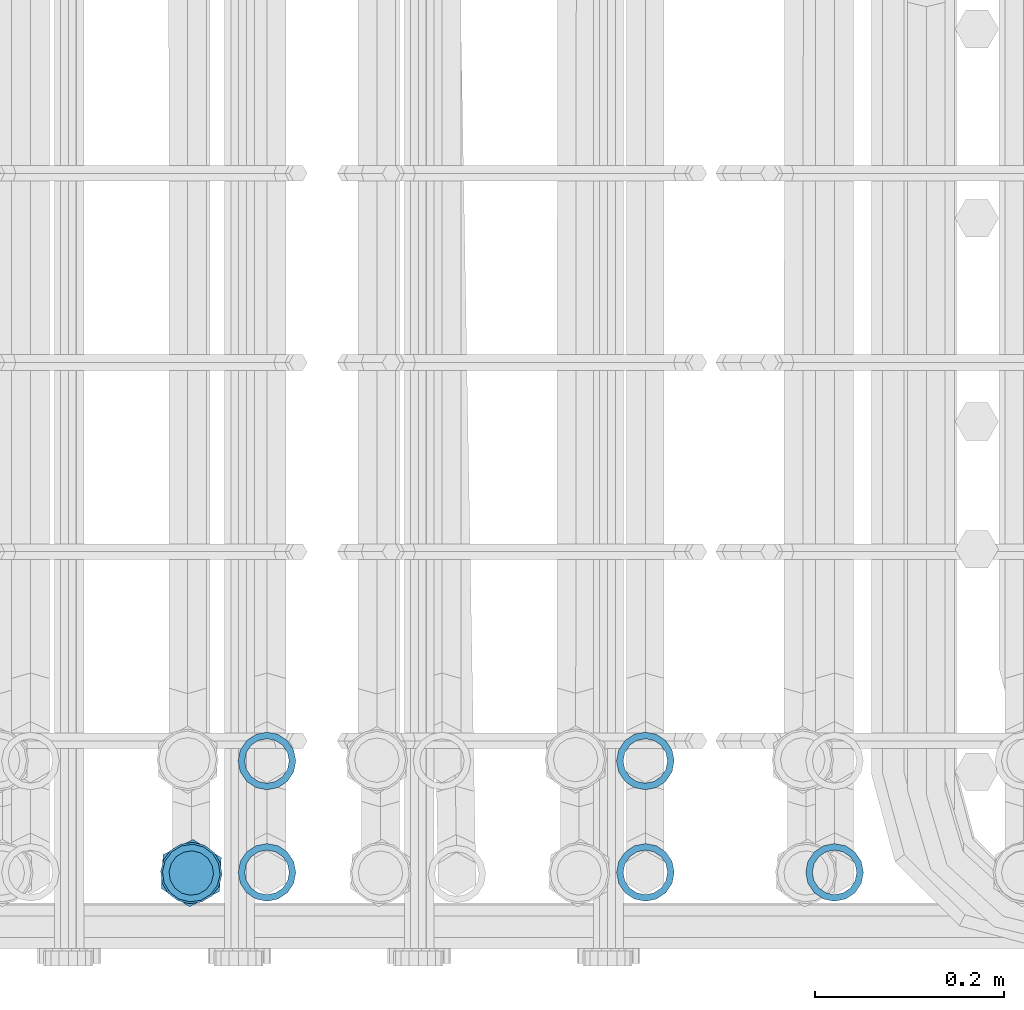
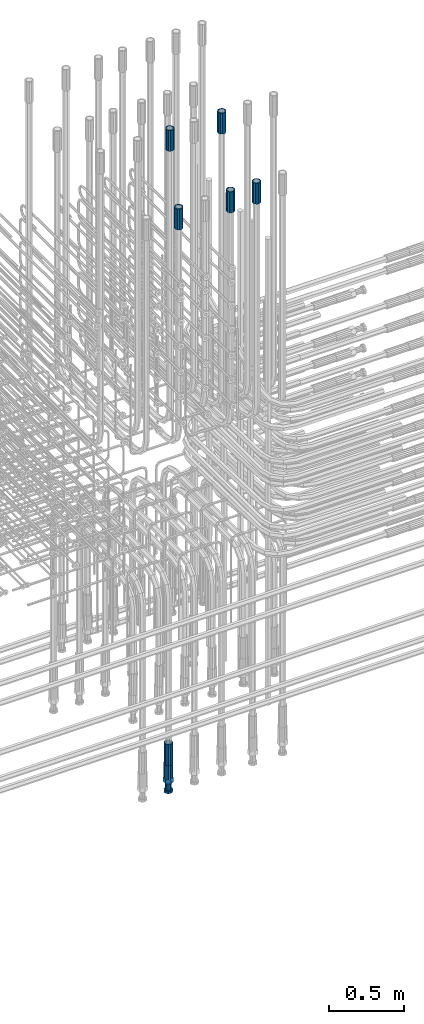
# One storey, part 93 of 177: 7 beams.
"""IFC2X3 building model written with IfcOpenShell, lengths in millimetres."""

import ifcopenshell
import ifcopenshell.guid

model = None  # the IFC model being written
_history = None  # IfcOwnerHistory: only IFC2X3 demands one
_inside = {}  # id of a spatial element -> (the spatial element, [elements in it])
_under = {}  # id of a project, library or spatial element -> (it, [spatial elements below it])
_declared = {}  # id of a project -> (the project, [libraries it declares])
_typed = {}  # id of a type object -> (the type object, [elements of that type])
_made_of = {}  # id of a material, layer set ... -> (it, [elements and type objects made of it])


def new_model(schema):
    """Start an empty IFC model of exactly this schema.

    Asked for "IFC4X3", IfcOpenShell would pick the latest addendum, in which some entities
    have other attributes; the version numbers below select the first issue.
    IFC2X3 requires an IfcOwnerHistory on every rooted entity: one is made here for all.
    """
    global model, _history
    if schema == "IFC4X3":
        model = ifcopenshell.file(schema_version=(4, 3, 0, 0))
    else:
        model = ifcopenshell.file(schema=schema)
    _inside.clear()
    _under.clear()
    _declared.clear()
    _typed.clear()
    _made_of.clear()
    _history = None
    if model.schema == "IFC2X3":
        org = make("IfcOrganization", Name="unknown")
        user = make(
            "IfcPersonAndOrganization",
            ThePerson=make("IfcPerson", FamilyName="unknown"),
            TheOrganization=org,
        )
        app = make(
            "IfcApplication",
            ApplicationDeveloper=org,
            Version="unknown",
            ApplicationFullName="unknown",
            ApplicationIdentifier="unknown",
        )
        _history = make(
            "IfcOwnerHistory",
            OwningUser=user,
            OwningApplication=app,
            ChangeAction="ADDED",
            CreationDate=0,
        )
    return model


def make(cls, **values):
    """One entity of the class cls with the attributes given. An attribute that is None is left unset."""
    return model.create_entity(
        cls, **{name: value for name, value in values.items() if value is not None}
    )


def rooted(cls, **values):
    """An entity with a GlobalId (a new one), such as an element, a storey or a relation."""
    return make(cls, GlobalId=ifcopenshell.guid.new(), OwnerHistory=_history, **values)


def si_unit(unit_type, name, prefix=None):
    """IfcSIUnit, for example si_unit("LENGTHUNIT", "METRE", prefix="MILLI")."""
    return make("IfcSIUnit", UnitType=unit_type, Prefix=prefix, Name=name)


def assignment(units):
    """IfcUnitAssignment: the units of a project."""
    return None if units is None else make("IfcUnitAssignment", Units=units)


def point(xyz):
    """IfcCartesianPoint."""
    return None if xyz is None else make("IfcCartesianPoint", Coordinates=xyz)


def direction(xyz):
    """IfcDirection."""
    return None if xyz is None else make("IfcDirection", DirectionRatios=xyz)


def frame(location, z_axis=None, x_axis=None):
    """IfcAxis2Placement3D, a coordinate frame: its origin and axes. An axis left out is left unset."""
    return make(
        "IfcAxis2Placement3D",
        Location=point(location),
        Axis=direction(z_axis),
        RefDirection=direction(x_axis),
    )


def origin_with_axes():
    """The frame at (0, 0, 0) with the z axis (0, 0, 1) and the x axis (1, 0, 0) written out."""
    return frame((0.0, 0.0, 0.0), z_axis=(0.0, 0.0, 1.0), x_axis=(1.0, 0.0, 0.0))


def place(relative_to, where):
    """IfcLocalPlacement: puts the frame where relative to a parent placement (None: the world)."""
    return make(
        "IfcLocalPlacement", PlacementRelTo=relative_to, RelativePlacement=where
    )


def context(
    kind, dimensions, precision=None, world=None, true_north=None, identifier=None
):
    """IfcGeometricRepresentationContext, for example the 3D "Model" context."""
    return make(
        "IfcGeometricRepresentationContext",
        ContextIdentifier=identifier,
        ContextType=kind,
        CoordinateSpaceDimension=dimensions,
        Precision=precision,
        WorldCoordinateSystem=world,
        TrueNorth=true_north,
    )


def subcontext(parent, identifier, kind, view, scale=None):
    """IfcGeometricRepresentationSubContext, for example "Body" below "Model"."""
    return make(
        "IfcGeometricRepresentationSubContext",
        ContextIdentifier=identifier,
        ContextType=kind,
        ParentContext=parent,
        TargetScale=scale,
        TargetView=view,
    )


def project(units=None, contexts=None):
    """IfcProject with its units and contexts."""
    return rooted(
        "IfcProject",
        Name="project",
        RepresentationContexts=contexts,
        UnitsInContext=assignment(units),
    )


def spatial(cls, under=None, at=None, **own):
    """A site, building, storey or space (cls), placed at a placement, below another one or the project."""
    s = rooted(cls, ObjectPlacement=at, **own)
    if under is not None:
        _under.setdefault(under.id(), (under, []))[1].append(s)
    return s


def faces_of(points, faces, orient=None, outer=None):
    """IfcFace entities. A face is a list of loops; a loop is a list of indices into points, from 0.

    orient and outer hold one flag for each loop. By default every Orientation is true, the
    first loop of a face is its IfcFaceOuterBound and the others are IfcFaceBound.
    """
    made = []
    for i, loops in enumerate(faces):
        bounds = []
        for j, loop in enumerate(loops):
            is_outer = j == 0 if outer is None else outer[i][j]
            bounds.append(
                make(
                    "IfcFaceOuterBound" if is_outer else "IfcFaceBound",
                    Bound=make("IfcPolyLoop", Polygon=[points[k] for k in loop]),
                    Orientation=True if orient is None else orient[i][j],
                )
            )
        made.append(make("IfcFace", Bounds=bounds))
    return made


def faceted_brep(points, faces, orient=None, outer=None, voids=None):
    """IfcFacetedBrep: a solid bounded by flat faces; with voids (closed shells), ...WithVoids."""
    shared = [point(p) for p in points]
    hull = make("IfcClosedShell", CfsFaces=faces_of(shared, faces, orient, outer))
    if voids is None:
        return make("IfcFacetedBrep", Outer=hull)
    return make(
        "IfcFacetedBrepWithVoids",
        Outer=hull,
        Voids=[
            make(cls, CfsFaces=faces_of(shared, fs, o, b)) for cls, fs, o, b in voids
        ],
    )


def shape(context_of_items, identifier, shape_type, items):
    """IfcShapeRepresentation: the items that make up one representation, for example the "Body"."""
    return make(
        "IfcShapeRepresentation",
        ContextOfItems=context_of_items,
        RepresentationIdentifier=identifier,
        RepresentationType=shape_type,
        Items=items,
    )


def material(Name=None, Category=None):
    """IfcMaterial."""
    return make("IfcMaterial", Name=Name, Category=Category)


def made_of(thing, what):
    """Note that an element or type object is made of a material, layer set ...; save() writes the relation."""
    if what is not None:
        _made_of.setdefault(what.id(), (what, []))[1].append(thing)
    return thing


def type_object(cls, material=None, **own):
    """A type object (cls), such as IfcWallType, which elements share."""
    return made_of(rooted(cls, **own), material)


def element(
    cls,
    number,
    at=None,
    inside=None,
    cuts=None,
    type_object=None,
    material=None,
    context=None,
    identifier="Body",
    shape_type=None,
    held_by="IfcProductDefinitionShape",
    body=None,
    shapes=None,
    **own,
):
    """One element of the class cls, such as IfcWall. Its Tag is "e" and its number.

    at: its placement. inside: the storey or other place that contains it. cuts: it is an
    opening in that element (IfcRelVoidsElement). A single representation is given by context,
    identifier, shape_type and body (its items); several are given by shapes. held_by: the class
    of the entity that holds the representations. save() writes the other relations.
    """
    e = rooted(cls, Tag="e%d" % number, ObjectPlacement=at, **own)
    if body is not None:
        shapes = [shape(context, identifier, shape_type, body)]
    if shapes is not None:
        e.Representation = make(held_by, Representations=shapes)
    if inside is not None:
        _inside.setdefault(inside.id(), (inside, []))[1].append(e)
    if cuts is not None:
        rooted(
            "IfcRelVoidsElement", RelatingBuildingElement=cuts, RelatedOpeningElement=e
        )
    if type_object is not None:
        _typed.setdefault(type_object.id(), (type_object, []))[1].append(e)
    return made_of(e, material)


def aggregate(whole, parts):
    """IfcRelAggregates: a whole, such as a stair, and the parts it consists of."""
    return rooted("IfcRelAggregates", RelatingObject=whole, RelatedObjects=parts)


def save(model, path):
    """Write the relations noted so far, then the file.

    IfcRelAggregates (storeys below a building ...), IfcRelContainedInSpatialStructure (elements
    in a storey), IfcRelDefinesByType, IfcRelAssociatesMaterial and IfcRelDeclares: one each for
    every whole, place, type object, material and project.
    """
    for whole, parts in _under.values():
        aggregate(whole, parts)
    for where, things in _inside.values():
        rooted(
            "IfcRelContainedInSpatialStructure",
            RelatedElements=things,
            RelatingStructure=where,
        )
    for kind, things in _typed.values():
        rooted("IfcRelDefinesByType", RelatedObjects=things, RelatingType=kind)
    for what, things in _made_of.values():
        rooted("IfcRelAssociatesMaterial", RelatedObjects=things, RelatingMaterial=what)
    for by, libraries in _declared.values():
        rooted("IfcRelDeclares", RelatingContext=by, RelatedDefinitions=libraries)
    model.write(path)


model = new_model("IFC2X3")

# Units and contexts
model_context_1 = context("Model", 3, precision=1e-05, world=origin_with_axes())
model_context_2 = context("Model", 3, precision=1e-05, world=origin_with_axes())
body_context = subcontext(model_context_2, "Body", "Model", "MODEL_VIEW")
ifc_project = project(units=[si_unit("LENGTHUNIT", "METRE", prefix="MILLI"), si_unit("AREAUNIT", "SQUARE_METRE"), si_unit("VOLUMEUNIT", "CUBIC_METRE"), si_unit("MASSUNIT", "GRAM", prefix="KILO"), si_unit("TIMEUNIT", "SECOND"), si_unit("PLANEANGLEUNIT", "RADIAN"), si_unit("SOLIDANGLEUNIT", "STERADIAN"), si_unit("THERMODYNAMICTEMPERATUREUNIT", "DEGREE_CELSIUS"), si_unit("LUMINOUSINTENSITYUNIT", "LUMEN")], contexts=[model_context_1])

# Site, building, storey
site_placement = place(None, origin_with_axes())
site = spatial("IfcSite", under=ifc_project, at=site_placement, CompositionType="ELEMENT")
building_placement = place(site_placement, origin_with_axes())
building = spatial("IfcBuilding", under=site, at=building_placement, Name="Undefined", CompositionType="ELEMENT")
storey_placement = place(building_placement, origin_with_axes())
storey = spatial("IfcBuildingStorey", under=building, at=storey_placement, Name="Undefined", CompositionType="ELEMENT", Elevation=0.0)

# Beams
ifc_material = material(Name="STEEL/S275")
beam_type_1 = type_object("IfcBeamType", PredefinedType="NOTDEFINED")
beam_1_placement = place(storey_placement, frame((2036955.98614598, 6205155.71450967, 18490.9770902109), z_axis=(-0.998629534810524, 0.0523359549893053, -4.41290963135532e-06), x_axis=(4.41099982681893e-06, -1.51997322536097e-07, -0.99999999999026)))
element("IfcBeam", 1, at=beam_1_placement, inside=storey, type_object=beam_type_1, material=ifc_material, Name="AG40N", context=body_context, shape_type="Brep", body=[
    faceted_brep([(0.0, -23.5000000001164, -9.31322574615479e-10), (0.0, -21.7111690140155, 8.99306066054851), (170.0, -21.7111690140155, 8.99306066054851), (170.0, -23.5, 0.0), (0.0, -16.6170093578839, 16.6170093575493), (170.0, -16.6170093578839, 16.6170093575493), (0.0, -8.99306066057943, 21.7111690137535), (170.0, -8.99306066057943, 21.7111690137535), (0.0, 1.16415321826935e-10, 23.5), (170.0, 0.0, 23.5), (0.0, 8.99306066057943, 21.7111690137535), (170.0, 8.99306066057943, 21.7111690137535), (0.0, 16.6170093578839, 16.6170093575493), (170.0, 16.6170093578839, 16.6170093575493), (0.0, 21.7111690140155, 8.99306066054851), (170.0, 21.7111690140155, 8.99306066054851), (0.0, 23.5000000001164, -9.31322574615479e-10), (170.0, 23.5, 0.0), (0.0, 21.7111690140155, -8.99306066054851), (170.0, 21.7111690140155, -8.99306066054851), (0.0, 16.6170093578839, -16.6170093575493), (170.0, 16.6170093578839, -16.6170093575493), (0.0, 8.99306066057943, -21.7111690137535), (170.0, 8.99306066057943, -21.7111690137535), (0.0, 1.16415321826935e-10, -23.5000000009313), (170.0, 0.0, -23.5), (0.0, -8.99306066057943, -21.7111690137535), (170.0, -8.99306066057943, -21.7111690137535), (0.0, -16.6170093578839, -16.6170093575493), (170.0, -16.6170093578839, -16.6170093575493), (0.0, -21.7111690140155, -8.99306066054851), (170.0, -21.7111690140155, -8.99306066054851), (0.0, -30.5, 0.0), (0.0, -28.1783257415937, -11.6718446873128), (170.0, -28.1783257415937, -11.6718446873128), (170.0, -30.5, 0.0), (0.0, -21.5667568261888, -21.5667568258941), (170.0, -21.5667568261888, -21.5667568258941), (0.0, -11.6718446871346, -28.1783257415518), (170.0, -11.6718446871346, -28.1783257415518), (0.0, 0.0, -30.5), (170.0, 0.0, -30.5), (0.0, 11.6718446871346, -28.1783257415518), (170.0, 11.6718446871346, -28.1783257415518), (0.0, 21.5667568261888, -21.5667568258941), (170.0, 21.5667568261888, -21.5667568258941), (0.0, 28.1783257415937, -11.6718446873128), (170.0, 28.1783257415937, -11.6718446873128), (0.0, 30.5, 0.0), (170.0, 30.5, 0.0), (0.0, 28.1783257415937, 11.6718446873128), (170.0, 28.1783257415937, 11.6718446873128), (0.0, 21.5667568261888, 21.5667568258941), (170.0, 21.5667568261888, 21.5667568258941), (0.0, 11.6718446871346, 28.1783257415518), (170.0, 11.6718446871346, 28.1783257415518), (0.0, 0.0, 30.5), (170.0, 0.0, 30.5), (0.0, -11.6718446871346, 28.1783257415518), (170.0, -11.6718446871346, 28.1783257415518), (0.0, -21.5667568261888, 21.5667568258941), (170.0, -21.5667568261888, 21.5667568258941), (0.0, -28.1783257415937, 11.6718446873128), (170.0, -28.1783257415937, 11.6718446873128)], [[[0, 1, 2, 3]], [[1, 4, 5, 2]], [[4, 6, 7, 5]], [[6, 8, 9, 7]], [[8, 10, 11, 9]], [[10, 12, 13, 11]], [[12, 14, 15, 13]], [[14, 16, 17, 15]], [[16, 18, 19, 17]], [[18, 20, 21, 19]], [[20, 22, 23, 21]], [[22, 24, 25, 23]], [[24, 26, 27, 25]], [[26, 28, 29, 27]], [[28, 30, 31, 29]], [[30, 0, 3, 31]], [[32, 33, 34, 35]], [[33, 36, 37, 34]], [[36, 38, 39, 37]], [[38, 40, 41, 39]], [[40, 42, 43, 41]], [[42, 44, 45, 43]], [[44, 46, 47, 45]], [[46, 48, 49, 47]], [[48, 50, 51, 49]], [[50, 52, 53, 51]], [[52, 54, 55, 53]], [[54, 56, 57, 55]], [[56, 58, 59, 57]], [[58, 60, 61, 59]], [[60, 62, 63, 61]], [[62, 32, 35, 63]], [[37, 39, 41, 43, 45, 47, 49, 51, 53, 55, 57, 59, 61, 63, 35, 34], [5, 7, 9, 11, 13, 15, 17, 19, 21, 23, 25, 27, 29, 31, 3, 2]], [[62, 60, 58, 56, 54, 52, 50, 48, 46, 44, 42, 40, 38, 36, 33, 32], [30, 28, 26, 24, 22, 20, 18, 16, 14, 12, 10, 8, 6, 4, 1, 0]]]),
])
beam_2_placement = place(storey_placement, frame((2037036.02583894, 6205156.40965299, 22659.9909079055), z_axis=(1.0, 0.0, 0.0), x_axis=(0.0, 0.0, 1.0)))
element("IfcBeam", 2, at=beam_2_placement, inside=storey, type_object=beam_type_1, material=ifc_material, Name="AG40N", context=body_context, shape_type="Brep", body=[
    faceted_brep([(0.0, -23.5000000001164, -9.31322574615479e-10), (0.0, -21.7111690140155, 8.99306066054851), (170.0, -21.7111690140155, 8.99306066054851), (170.0, -23.5, 0.0), (0.0, -16.6170093578839, 16.6170093575493), (170.0, -16.6170093578839, 16.6170093575493), (0.0, -8.99306066057943, 21.7111690137535), (170.0, -8.99306066057943, 21.7111690137535), (0.0, 1.16415321826935e-10, 23.5), (170.0, 0.0, 23.5), (0.0, 8.99306066057943, 21.7111690137535), (170.0, 8.99306066057943, 21.7111690137535), (0.0, 16.6170093578839, 16.6170093575493), (170.0, 16.6170093578839, 16.6170093575493), (0.0, 21.7111690140155, 8.99306066054851), (170.0, 21.7111690140155, 8.99306066054851), (0.0, 23.5000000001164, -9.31322574615479e-10), (170.0, 23.5, 0.0), (0.0, 21.7111690140155, -8.99306066054851), (170.0, 21.7111690140155, -8.99306066054851), (0.0, 16.6170093578839, -16.6170093575493), (170.0, 16.6170093578839, -16.6170093575493), (0.0, 8.99306066057943, -21.7111690137535), (170.0, 8.99306066057943, -21.7111690137535), (0.0, 1.16415321826935e-10, -23.5000000009313), (170.0, 0.0, -23.5), (0.0, -8.99306066057943, -21.7111690137535), (170.0, -8.99306066057943, -21.7111690137535), (0.0, -16.6170093578839, -16.6170093575493), (170.0, -16.6170093578839, -16.6170093575493), (0.0, -21.7111690140155, -8.99306066054851), (170.0, -21.7111690140155, -8.99306066054851), (0.0, -30.5, 0.0), (0.0, -28.1783257415937, -11.6718446873128), (170.0, -28.1783257415937, -11.6718446873128), (170.0, -30.5, 0.0), (0.0, -21.5667568261888, -21.5667568258941), (170.0, -21.5667568261888, -21.5667568258941), (0.0, -11.6718446871346, -28.1783257415518), (170.0, -11.6718446871346, -28.1783257415518), (0.0, 0.0, -30.5), (170.0, 0.0, -30.5), (0.0, 11.6718446871346, -28.1783257415518), (170.0, 11.6718446871346, -28.1783257415518), (0.0, 21.5667568261888, -21.5667568258941), (170.0, 21.5667568261888, -21.5667568258941), (0.0, 28.1783257415937, -11.6718446873128), (170.0, 28.1783257415937, -11.6718446873128), (0.0, 30.5, 0.0), (170.0, 30.5, 0.0), (0.0, 28.1783257415937, 11.6718446873128), (170.0, 28.1783257415937, 11.6718446873128), (0.0, 21.5667568261888, 21.5667568258941), (170.0, 21.5667568261888, 21.5667568258941), (0.0, 11.6718446871346, 28.1783257415518), (170.0, 11.6718446871346, 28.1783257415518), (0.0, 0.0, 30.5), (170.0, 0.0, 30.5), (0.0, -11.6718446871346, 28.1783257415518), (170.0, -11.6718446871346, 28.1783257415518), (0.0, -21.5667568261888, 21.5667568258941), (170.0, -21.5667568261888, 21.5667568258941), (0.0, -28.1783257415937, 11.6718446873128), (170.0, -28.1783257415937, 11.6718446873128)], [[[0, 1, 2, 3]], [[1, 4, 5, 2]], [[4, 6, 7, 5]], [[6, 8, 9, 7]], [[8, 10, 11, 9]], [[10, 12, 13, 11]], [[12, 14, 15, 13]], [[14, 16, 17, 15]], [[16, 18, 19, 17]], [[18, 20, 21, 19]], [[20, 22, 23, 21]], [[22, 24, 25, 23]], [[24, 26, 27, 25]], [[26, 28, 29, 27]], [[28, 30, 31, 29]], [[30, 0, 3, 31]], [[32, 33, 34, 35]], [[33, 36, 37, 34]], [[36, 38, 39, 37]], [[38, 40, 41, 39]], [[40, 42, 43, 41]], [[42, 44, 45, 43]], [[44, 46, 47, 45]], [[46, 48, 49, 47]], [[48, 50, 51, 49]], [[50, 52, 53, 51]], [[52, 54, 55, 53]], [[54, 56, 57, 55]], [[56, 58, 59, 57]], [[58, 60, 61, 59]], [[60, 62, 63, 61]], [[62, 32, 35, 63]], [[37, 39, 41, 43, 45, 47, 49, 51, 53, 55, 57, 59, 61, 63, 35, 34], [5, 7, 9, 11, 13, 15, 17, 19, 21, 23, 25, 27, 29, 31, 3, 2]], [[62, 60, 58, 56, 54, 52, 50, 48, 46, 44, 42, 40, 38, 36, 33, 32], [30, 28, 26, 24, 22, 20, 18, 16, 14, 12, 10, 8, 6, 4, 1, 0]]]),
])
beam_3_placement = place(storey_placement, frame((2037436.02583894, 6205156.40965114, 22659.9909079055), z_axis=(1.0, 0.0, 0.0), x_axis=(0.0, 0.0, 1.0)))
element("IfcBeam", 3, at=beam_3_placement, inside=storey, type_object=beam_type_1, material=ifc_material, Name="AG40N", context=body_context, shape_type="Brep", body=[
    faceted_brep([(0.0, -23.5000000001164, -9.31322574615479e-10), (0.0, -21.7111690140155, 8.99306066054851), (170.0, -21.7111690140155, 8.99306066054851), (170.0, -23.5, 0.0), (0.0, -16.6170093578839, 16.6170093575493), (170.0, -16.6170093578839, 16.6170093575493), (0.0, -8.99306066057943, 21.7111690137535), (170.0, -8.99306066057943, 21.7111690137535), (0.0, 1.16415321826935e-10, 23.5), (170.0, 0.0, 23.5), (0.0, 8.99306066057943, 21.7111690137535), (170.0, 8.99306066057943, 21.7111690137535), (0.0, 16.6170093578839, 16.6170093575493), (170.0, 16.6170093578839, 16.6170093575493), (0.0, 21.7111690140155, 8.99306066054851), (170.0, 21.7111690140155, 8.99306066054851), (0.0, 23.5000000001164, -9.31322574615479e-10), (170.0, 23.5, 0.0), (0.0, 21.7111690140155, -8.99306066054851), (170.0, 21.7111690140155, -8.99306066054851), (0.0, 16.6170093578839, -16.6170093575493), (170.0, 16.6170093578839, -16.6170093575493), (0.0, 8.99306066057943, -21.7111690137535), (170.0, 8.99306066057943, -21.7111690137535), (0.0, 1.16415321826935e-10, -23.5000000009313), (170.0, 0.0, -23.5), (0.0, -8.99306066057943, -21.7111690137535), (170.0, -8.99306066057943, -21.7111690137535), (0.0, -16.6170093578839, -16.6170093575493), (170.0, -16.6170093578839, -16.6170093575493), (0.0, -21.7111690140155, -8.99306066054851), (170.0, -21.7111690140155, -8.99306066054851), (0.0, -30.5, 0.0), (0.0, -28.1783257415937, -11.6718446873128), (170.0, -28.1783257415937, -11.6718446873128), (170.0, -30.5, 0.0), (0.0, -21.5667568261888, -21.5667568258941), (170.0, -21.5667568261888, -21.5667568258941), (0.0, -11.6718446871346, -28.1783257415518), (170.0, -11.6718446871346, -28.1783257415518), (0.0, 0.0, -30.5), (170.0, 0.0, -30.5), (0.0, 11.6718446871346, -28.1783257415518), (170.0, 11.6718446871346, -28.1783257415518), (0.0, 21.5667568261888, -21.5667568258941), (170.0, 21.5667568261888, -21.5667568258941), (0.0, 28.1783257415937, -11.6718446873128), (170.0, 28.1783257415937, -11.6718446873128), (0.0, 30.5, 0.0), (170.0, 30.5, 0.0), (0.0, 28.1783257415937, 11.6718446873128), (170.0, 28.1783257415937, 11.6718446873128), (0.0, 21.5667568261888, 21.5667568258941), (170.0, 21.5667568261888, 21.5667568258941), (0.0, 11.6718446871346, 28.1783257415518), (170.0, 11.6718446871346, 28.1783257415518), (0.0, 0.0, 30.5), (170.0, 0.0, 30.5), (0.0, -11.6718446871346, 28.1783257415518), (170.0, -11.6718446871346, 28.1783257415518), (0.0, -21.5667568261888, 21.5667568258941), (170.0, -21.5667568261888, 21.5667568258941), (0.0, -28.1783257415937, 11.6718446873128), (170.0, -28.1783257415937, 11.6718446873128)], [[[0, 1, 2, 3]], [[1, 4, 5, 2]], [[4, 6, 7, 5]], [[6, 8, 9, 7]], [[8, 10, 11, 9]], [[10, 12, 13, 11]], [[12, 14, 15, 13]], [[14, 16, 17, 15]], [[16, 18, 19, 17]], [[18, 20, 21, 19]], [[20, 22, 23, 21]], [[22, 24, 25, 23]], [[24, 26, 27, 25]], [[26, 28, 29, 27]], [[28, 30, 31, 29]], [[30, 0, 3, 31]], [[32, 33, 34, 35]], [[33, 36, 37, 34]], [[36, 38, 39, 37]], [[38, 40, 41, 39]], [[40, 42, 43, 41]], [[42, 44, 45, 43]], [[44, 46, 47, 45]], [[46, 48, 49, 47]], [[48, 50, 51, 49]], [[50, 52, 53, 51]], [[52, 54, 55, 53]], [[54, 56, 57, 55]], [[56, 58, 59, 57]], [[58, 60, 61, 59]], [[60, 62, 63, 61]], [[62, 32, 35, 63]], [[37, 39, 41, 43, 45, 47, 49, 51, 53, 55, 57, 59, 61, 63, 35, 34], [5, 7, 9, 11, 13, 15, 17, 19, 21, 23, 25, 27, 29, 31, 3, 2]], [[62, 60, 58, 56, 54, 52, 50, 48, 46, 44, 42, 40, 38, 36, 33, 32], [30, 28, 26, 24, 22, 20, 18, 16, 14, 12, 10, 8, 6, 4, 1, 0]]]),
])
beam_4_placement = place(storey_placement, frame((2037636.02583894, 6205156.40965025, 22659.9909079055), z_axis=(1.0, 0.0, 0.0), x_axis=(0.0, 0.0, 1.0)))
element("IfcBeam", 4, at=beam_4_placement, inside=storey, type_object=beam_type_1, material=ifc_material, Name="AG40N", context=body_context, shape_type="Brep", body=[
    faceted_brep([(0.0, -23.5000000001164, -9.31322574615479e-10), (0.0, -21.7111690140155, 8.99306066054851), (170.0, -21.7111690140155, 8.99306066054851), (170.0, -23.5, 0.0), (0.0, -16.6170093578839, 16.6170093575493), (170.0, -16.6170093578839, 16.6170093575493), (0.0, -8.99306066057943, 21.7111690137535), (170.0, -8.99306066057943, 21.7111690137535), (0.0, 1.16415321826935e-10, 23.5), (170.0, 0.0, 23.5), (0.0, 8.99306066057943, 21.7111690137535), (170.0, 8.99306066057943, 21.7111690137535), (0.0, 16.6170093578839, 16.6170093575493), (170.0, 16.6170093578839, 16.6170093575493), (0.0, 21.7111690140155, 8.99306066054851), (170.0, 21.7111690140155, 8.99306066054851), (0.0, 23.5000000001164, -9.31322574615479e-10), (170.0, 23.5, 0.0), (0.0, 21.7111690140155, -8.99306066054851), (170.0, 21.7111690140155, -8.99306066054851), (0.0, 16.6170093578839, -16.6170093575493), (170.0, 16.6170093578839, -16.6170093575493), (0.0, 8.99306066057943, -21.7111690137535), (170.0, 8.99306066057943, -21.7111690137535), (0.0, 1.16415321826935e-10, -23.5000000009313), (170.0, 0.0, -23.5), (0.0, -8.99306066057943, -21.7111690137535), (170.0, -8.99306066057943, -21.7111690137535), (0.0, -16.6170093578839, -16.6170093575493), (170.0, -16.6170093578839, -16.6170093575493), (0.0, -21.7111690140155, -8.99306066054851), (170.0, -21.7111690140155, -8.99306066054851), (0.0, -30.5, 0.0), (0.0, -28.1783257415937, -11.6718446873128), (170.0, -28.1783257415937, -11.6718446873128), (170.0, -30.5, 0.0), (0.0, -21.5667568261888, -21.5667568258941), (170.0, -21.5667568261888, -21.5667568258941), (0.0, -11.6718446871346, -28.1783257415518), (170.0, -11.6718446871346, -28.1783257415518), (0.0, 0.0, -30.5), (170.0, 0.0, -30.5), (0.0, 11.6718446871346, -28.1783257415518), (170.0, 11.6718446871346, -28.1783257415518), (0.0, 21.5667568261888, -21.5667568258941), (170.0, 21.5667568261888, -21.5667568258941), (0.0, 28.1783257415937, -11.6718446873128), (170.0, 28.1783257415937, -11.6718446873128), (0.0, 30.5, 0.0), (170.0, 30.5, 0.0), (0.0, 28.1783257415937, 11.6718446873128), (170.0, 28.1783257415937, 11.6718446873128), (0.0, 21.5667568261888, 21.5667568258941), (170.0, 21.5667568261888, 21.5667568258941), (0.0, 11.6718446871346, 28.1783257415518), (170.0, 11.6718446871346, 28.1783257415518), (0.0, 0.0, 30.5), (170.0, 0.0, 30.5), (0.0, -11.6718446871346, 28.1783257415518), (170.0, -11.6718446871346, 28.1783257415518), (0.0, -21.5667568261888, 21.5667568258941), (170.0, -21.5667568261888, 21.5667568258941), (0.0, -28.1783257415937, 11.6718446873128), (170.0, -28.1783257415937, 11.6718446873128)], [[[0, 1, 2, 3]], [[1, 4, 5, 2]], [[4, 6, 7, 5]], [[6, 8, 9, 7]], [[8, 10, 11, 9]], [[10, 12, 13, 11]], [[12, 14, 15, 13]], [[14, 16, 17, 15]], [[16, 18, 19, 17]], [[18, 20, 21, 19]], [[20, 22, 23, 21]], [[22, 24, 25, 23]], [[24, 26, 27, 25]], [[26, 28, 29, 27]], [[28, 30, 31, 29]], [[30, 0, 3, 31]], [[32, 33, 34, 35]], [[33, 36, 37, 34]], [[36, 38, 39, 37]], [[38, 40, 41, 39]], [[40, 42, 43, 41]], [[42, 44, 45, 43]], [[44, 46, 47, 45]], [[46, 48, 49, 47]], [[48, 50, 51, 49]], [[50, 52, 53, 51]], [[52, 54, 55, 53]], [[54, 56, 57, 55]], [[56, 58, 59, 57]], [[58, 60, 61, 59]], [[60, 62, 63, 61]], [[62, 32, 35, 63]], [[37, 39, 41, 43, 45, 47, 49, 51, 53, 55, 57, 59, 61, 63, 35, 34], [5, 7, 9, 11, 13, 15, 17, 19, 21, 23, 25, 27, 29, 31, 3, 2]], [[62, 60, 58, 56, 54, 52, 50, 48, 46, 44, 42, 40, 38, 36, 33, 32], [30, 28, 26, 24, 22, 20, 18, 16, 14, 12, 10, 8, 6, 4, 1, 0]]]),
])
beam_5_placement = place(storey_placement, frame((2037035.98583793, 6205274.18965174, 23229.9909142034), z_axis=(1.0, 0.0, 0.0), x_axis=(0.0, 0.0, 1.0)))
element("IfcBeam", 5, at=beam_5_placement, inside=storey, type_object=beam_type_1, material=ifc_material, Name="AG40N", context=body_context, shape_type="Brep", body=[
    faceted_brep([(0.0, -23.5000000001164, -9.31322574615479e-10), (0.0, -21.7111690140155, 8.99306066054851), (170.0, -21.7111690140155, 8.99306066054851), (170.0, -23.5, 0.0), (0.0, -16.6170093578839, 16.6170093575493), (170.0, -16.6170093578839, 16.6170093575493), (0.0, -8.99306066057943, 21.7111690137535), (170.0, -8.99306066057943, 21.7111690137535), (0.0, 1.16415321826935e-10, 23.5), (170.0, 0.0, 23.5), (0.0, 8.99306066057943, 21.7111690137535), (170.0, 8.99306066057943, 21.7111690137535), (0.0, 16.6170093578839, 16.6170093575493), (170.0, 16.6170093578839, 16.6170093575493), (0.0, 21.7111690140155, 8.99306066054851), (170.0, 21.7111690140155, 8.99306066054851), (0.0, 23.5000000001164, -9.31322574615479e-10), (170.0, 23.5, 0.0), (0.0, 21.7111690140155, -8.99306066054851), (170.0, 21.7111690140155, -8.99306066054851), (0.0, 16.6170093578839, -16.6170093575493), (170.0, 16.6170093578839, -16.6170093575493), (0.0, 8.99306066057943, -21.7111690137535), (170.0, 8.99306066057943, -21.7111690137535), (0.0, 1.16415321826935e-10, -23.5000000009313), (170.0, 0.0, -23.5), (0.0, -8.99306066057943, -21.7111690137535), (170.0, -8.99306066057943, -21.7111690137535), (0.0, -16.6170093578839, -16.6170093575493), (170.0, -16.6170093578839, -16.6170093575493), (0.0, -21.7111690140155, -8.99306066054851), (170.0, -21.7111690140155, -8.99306066054851), (0.0, -30.5, 0.0), (0.0, -28.1783257415937, -11.6718446873128), (170.0, -28.1783257415937, -11.6718446873128), (170.0, -30.5, 0.0), (0.0, -21.5667568261888, -21.5667568258941), (170.0, -21.5667568261888, -21.5667568258941), (0.0, -11.6718446871346, -28.1783257415518), (170.0, -11.6718446871346, -28.1783257415518), (0.0, 0.0, -30.5), (170.0, 0.0, -30.5), (0.0, 11.6718446871346, -28.1783257415518), (170.0, 11.6718446871346, -28.1783257415518), (0.0, 21.5667568261888, -21.5667568258941), (170.0, 21.5667568261888, -21.5667568258941), (0.0, 28.1783257415937, -11.6718446873128), (170.0, 28.1783257415937, -11.6718446873128), (0.0, 30.5, 0.0), (170.0, 30.5, 0.0), (0.0, 28.1783257415937, 11.6718446873128), (170.0, 28.1783257415937, 11.6718446873128), (0.0, 21.5667568261888, 21.5667568258941), (170.0, 21.5667568261888, 21.5667568258941), (0.0, 11.6718446871346, 28.1783257415518), (170.0, 11.6718446871346, 28.1783257415518), (0.0, 0.0, 30.5), (170.0, 0.0, 30.5), (0.0, -11.6718446871346, 28.1783257415518), (170.0, -11.6718446871346, 28.1783257415518), (0.0, -21.5667568261888, 21.5667568258941), (170.0, -21.5667568261888, 21.5667568258941), (0.0, -28.1783257415937, 11.6718446873128), (170.0, -28.1783257415937, 11.6718446873128)], [[[0, 1, 2, 3]], [[1, 4, 5, 2]], [[4, 6, 7, 5]], [[6, 8, 9, 7]], [[8, 10, 11, 9]], [[10, 12, 13, 11]], [[12, 14, 15, 13]], [[14, 16, 17, 15]], [[16, 18, 19, 17]], [[18, 20, 21, 19]], [[20, 22, 23, 21]], [[22, 24, 25, 23]], [[24, 26, 27, 25]], [[26, 28, 29, 27]], [[28, 30, 31, 29]], [[30, 0, 3, 31]], [[32, 33, 34, 35]], [[33, 36, 37, 34]], [[36, 38, 39, 37]], [[38, 40, 41, 39]], [[40, 42, 43, 41]], [[42, 44, 45, 43]], [[44, 46, 47, 45]], [[46, 48, 49, 47]], [[48, 50, 51, 49]], [[50, 52, 53, 51]], [[52, 54, 55, 53]], [[54, 56, 57, 55]], [[56, 58, 59, 57]], [[58, 60, 61, 59]], [[60, 62, 63, 61]], [[62, 32, 35, 63]], [[37, 39, 41, 43, 45, 47, 49, 51, 53, 55, 57, 59, 61, 63, 35, 34], [5, 7, 9, 11, 13, 15, 17, 19, 21, 23, 25, 27, 29, 31, 3, 2]], [[62, 60, 58, 56, 54, 52, 50, 48, 46, 44, 42, 40, 38, 36, 33, 32], [30, 28, 26, 24, 22, 20, 18, 16, 14, 12, 10, 8, 6, 4, 1, 0]]]),
])
beam_6_placement = place(storey_placement, frame((2037435.98583793, 6205274.18965113, 23229.9909142034), z_axis=(1.0, 0.0, 0.0), x_axis=(0.0, 0.0, 1.0)))
element("IfcBeam", 6, at=beam_6_placement, inside=storey, type_object=beam_type_1, material=ifc_material, Name="AG40N", context=body_context, shape_type="Brep", body=[
    faceted_brep([(0.0, -23.5000000001164, -9.31322574615479e-10), (0.0, -21.7111690140155, 8.99306066054851), (170.0, -21.7111690140155, 8.99306066054851), (170.0, -23.5, 0.0), (0.0, -16.6170093578839, 16.6170093575493), (170.0, -16.6170093578839, 16.6170093575493), (0.0, -8.99306066057943, 21.7111690137535), (170.0, -8.99306066057943, 21.7111690137535), (0.0, 1.16415321826935e-10, 23.5), (170.0, 0.0, 23.5), (0.0, 8.99306066057943, 21.7111690137535), (170.0, 8.99306066057943, 21.7111690137535), (0.0, 16.6170093578839, 16.6170093575493), (170.0, 16.6170093578839, 16.6170093575493), (0.0, 21.7111690140155, 8.99306066054851), (170.0, 21.7111690140155, 8.99306066054851), (0.0, 23.5000000001164, -9.31322574615479e-10), (170.0, 23.5, 0.0), (0.0, 21.7111690140155, -8.99306066054851), (170.0, 21.7111690140155, -8.99306066054851), (0.0, 16.6170093578839, -16.6170093575493), (170.0, 16.6170093578839, -16.6170093575493), (0.0, 8.99306066057943, -21.7111690137535), (170.0, 8.99306066057943, -21.7111690137535), (0.0, 1.16415321826935e-10, -23.5000000009313), (170.0, 0.0, -23.5), (0.0, -8.99306066057943, -21.7111690137535), (170.0, -8.99306066057943, -21.7111690137535), (0.0, -16.6170093578839, -16.6170093575493), (170.0, -16.6170093578839, -16.6170093575493), (0.0, -21.7111690140155, -8.99306066054851), (170.0, -21.7111690140155, -8.99306066054851), (0.0, -30.5, 0.0), (0.0, -28.1783257415937, -11.6718446873128), (170.0, -28.1783257415937, -11.6718446873128), (170.0, -30.5, 0.0), (0.0, -21.5667568261888, -21.5667568258941), (170.0, -21.5667568261888, -21.5667568258941), (0.0, -11.6718446871346, -28.1783257415518), (170.0, -11.6718446871346, -28.1783257415518), (0.0, 0.0, -30.5), (170.0, 0.0, -30.5), (0.0, 11.6718446871346, -28.1783257415518), (170.0, 11.6718446871346, -28.1783257415518), (0.0, 21.5667568261888, -21.5667568258941), (170.0, 21.5667568261888, -21.5667568258941), (0.0, 28.1783257415937, -11.6718446873128), (170.0, 28.1783257415937, -11.6718446873128), (0.0, 30.5, 0.0), (170.0, 30.5, 0.0), (0.0, 28.1783257415937, 11.6718446873128), (170.0, 28.1783257415937, 11.6718446873128), (0.0, 21.5667568261888, 21.5667568258941), (170.0, 21.5667568261888, 21.5667568258941), (0.0, 11.6718446871346, 28.1783257415518), (170.0, 11.6718446871346, 28.1783257415518), (0.0, 0.0, 30.5), (170.0, 0.0, 30.5), (0.0, -11.6718446871346, 28.1783257415518), (170.0, -11.6718446871346, 28.1783257415518), (0.0, -21.5667568261888, 21.5667568258941), (170.0, -21.5667568261888, 21.5667568258941), (0.0, -28.1783257415937, 11.6718446873128), (170.0, -28.1783257415937, 11.6718446873128)], [[[0, 1, 2, 3]], [[1, 4, 5, 2]], [[4, 6, 7, 5]], [[6, 8, 9, 7]], [[8, 10, 11, 9]], [[10, 12, 13, 11]], [[12, 14, 15, 13]], [[14, 16, 17, 15]], [[16, 18, 19, 17]], [[18, 20, 21, 19]], [[20, 22, 23, 21]], [[22, 24, 25, 23]], [[24, 26, 27, 25]], [[26, 28, 29, 27]], [[28, 30, 31, 29]], [[30, 0, 3, 31]], [[32, 33, 34, 35]], [[33, 36, 37, 34]], [[36, 38, 39, 37]], [[38, 40, 41, 39]], [[40, 42, 43, 41]], [[42, 44, 45, 43]], [[44, 46, 47, 45]], [[46, 48, 49, 47]], [[48, 50, 51, 49]], [[50, 52, 53, 51]], [[52, 54, 55, 53]], [[54, 56, 57, 55]], [[56, 58, 59, 57]], [[58, 60, 61, 59]], [[60, 62, 63, 61]], [[62, 32, 35, 63]], [[37, 39, 41, 43, 45, 47, 49, 51, 53, 55, 57, 59, 61, 63, 35, 34], [5, 7, 9, 11, 13, 15, 17, 19, 21, 23, 25, 27, 29, 31, 3, 2]], [[62, 60, 58, 56, 54, 52, 50, 48, 46, 44, 42, 40, 38, 36, 33, 32], [30, 28, 26, 24, 22, 20, 18, 16, 14, 12, 10, 8, 6, 4, 1, 0]]]),
])
beam_type_2 = type_object("IfcBeamType", Name="ROD65", PredefinedType="NOTDEFINED")
beam_7_placement = place(storey_placement, frame((2036955.98689465, 6205155.71448373, 18320.9770902017), z_axis=(-0.998629534810524, 0.0523359549893053, -4.41290963135532e-06), x_axis=(4.41099982681893e-06, -1.51997322536097e-07, -0.99999999999026)))
element("IfcBeam", 7, at=beam_7_placement, inside=storey, type_object=beam_type_2, material=ifc_material, Name="AGB40", ObjectType="ROD65", context=body_context, shape_type="Brep", body=[
    faceted_brep([(117.0, 8.17543110251427, 30.873805644922), (117.0, 17.8250000001863, 30.873805644922), (117.0, 22.0056958701462, 23.6326279877685), (117.0, 12.4372115517035, 30.0260848065373), (117.0, -17.8250000001863, 30.873805644922), (150.200000000186, -17.8250000001863, 30.873805644922), (150.200000000186, 17.8250000001863, 30.873805644922), (117.0, -8.17543110251427, 30.873805644922), (117.0, -12.4372115517035, 30.0260848065373), (117.0, -22.0056958701462, 23.6326279877685), (117.0, -35.6500000003725, 0.0), (150.200000000186, -35.6500000003725, 0.0), (117.0, -30.8443150008097, 8.32369058486074), (117.0, -32.5, 0.0), (117.0, -30.8443150008097, -8.32369058462791), (117.0, -17.8250000001863, -30.873805644922), (150.200000000186, -17.8250000001863, -30.873805644922), (117.0, -22.0056958701462, -23.6326279877685), (117.0, -12.4372115517035, -30.0260848065373), (117.0, -8.17543110251427, -30.873805644922), (117.0, 17.8250000001863, -30.873805644922), (150.200000000186, 17.8250000001863, -30.873805644922), (117.0, 8.17543110251427, -30.873805644922), (117.0, 22.0056958701462, -23.6326279877685), (117.0, 12.4372115517035, -30.0260848065373), (117.0, 35.6500000003725, 0.0), (150.200000000186, 35.6500000003725, 0.0), (117.0, 30.8443150008097, -8.32369058486074), (117.0, 30.8443150008097, 8.32369058462791), (117.0, 32.5, 0.0), (0.0, -22.9809703892097, 22.9809703885621), (0.0, -30.0260848058388, 12.4372115518636), (117.0, -30.0260848067701, 12.4372115519363), (117.0, -22.9809703882784, 22.9809703885112), (-2.3283064365387e-10, 22.9809703892097, -22.9809703885639), (-4.65661287307739e-10, 30.0260848077014, -12.4372115518672), (117.0, 30.0260848067701, -12.4372115519363), (117.0, 22.9809703882784, -22.9809703885112), (-2.3283064365387e-10, -30.0260848067701, -12.4372115518672), (-2.3283064365387e-10, -22.9809703892097, -22.9809703885621), (117.0, -22.9809703882784, -22.9809703885112), (117.0, -30.0260848067701, -12.4372115519363), (-2.3283064365387e-10, -12.4372115507722, 30.0260848066137), (-2.3283064365387e-10, 9.31322574615479e-10, 32.4999999999982), (-2.3283064365387e-10, 12.4372115526348, 30.0260848066137), (0.0, 22.9809703892097, 22.9809703885621), (-2.3283064365387e-10, 30.0260848077014, 12.4372115518636), (-2.3283064365387e-10, 32.5, 0.0), (-2.3283064365387e-10, 12.4372115526348, -30.0260848066173), (-2.3283064365387e-10, 9.31322574615479e-10, -32.5), (-2.3283064365387e-10, -12.4372115517035, -30.0260848066173), (-4.65661287307739e-10, -32.4999999990687, -1.81898940354586e-12), (117.0, 22.9809703882784, 22.9809703885112), (117.0, 30.0260848067701, 12.4372115519363), (117.0, 0.0, -32.5), (117.0, 0.0, 32.5), (150.200000000186, 10.5, -18.1865334794857), (150.200000000186, 0.0, -21.0), (150.200000000186, -10.5, -18.1865334794857), (150.200000000186, -18.18653347902, -10.5), (150.200000000186, -21.0, 0.0), (150.200000000186, -18.18653347902, 10.5), (150.200000000186, -10.5, 18.1865334794857), (150.200000000186, 0.0, 21.0), (150.200000000186, 10.5, 18.1865334794857), (150.200000000186, 18.18653347902, 10.5), (150.200000000186, 21.0, 0.0), (150.200000000186, 18.18653347902, -10.5), (210.980000000447, -10.5, -18.1865334794857), (210.980000000447, 0.0, -21.0), (210.980000000447, -18.18653347902, -10.5), (210.980000000447, -21.0, 0.0), (210.980000000447, -18.18653347902, 10.5), (210.980000000447, -10.5, 18.1865334794857), (210.980000000447, 0.0, 21.0), (210.980000000447, 10.5, 18.1865334794857), (210.980000000447, 18.18653347902, 10.5), (210.980000000447, 21.0, 0.0), (210.980000000447, 18.18653347902, -10.5), (210.980000000447, 10.5, -18.1865334794857), (211.001368442696, -27.7269937992096, -11.491116326768), (211.003082550167, -21.2238094303757, -21.223815418547), (231.002518367059, -21.2131944671273, -21.2132004550658), (231.000804259587, -27.7163788359612, -11.4805013632867), (211.001368440451, -11.4911085031927, -27.7269970395137), (231.000804257343, -11.4804935399443, -27.7163820760325), (210.996487071217, -0.0106065049767494, -30.0106107392348), (230.995922888109, 8.45827162265778e-06, -29.9999957757536), (210.989181586672, 11.46989420522, -27.7269970329944), (230.988617403564, 11.4805091684684, -27.7163820695132), (210.980564180623, 21.2025914648548, -21.2238154064398), (230.979999997515, 21.2132064281031, -21.2132004429586), (210.971946775022, 27.7057703435421, -11.4911163107026), (230.971382591913, 27.7163853067905, -11.4805013472214), (210.96464129175, 29.9893808094785, -0.0106149562634528), (230.964077108642, 29.9999957727268, 7.21774995326996e-09), (210.959759924415, 27.7057638689876, 11.4698863970116), (230.959195741307, 27.7163788322359, 11.4805013604928), (210.958045816944, 21.2025795001537, 21.2025854887906), (230.957481633835, 21.213194463402, 21.2132004522718), (210.95975992666, 11.4698785729706, 27.7057671097573), (230.959195743551, 11.480493536219, 27.7163820732385), (210.964641295894, -0.010623425245285, 29.9893808094785), (230.964077112785, -8.46199691295624e-06, 29.9999957729597), (210.971946780439, -11.4911241354421, 27.705767103238), (230.97138259733, -11.4805091721937, 27.7163820667192), (210.980564186488, -21.2238213950768, 21.2025854766835), (230.980000003379, -21.2132064318284, 21.2132004401647), (210.989181592089, -27.7270002737641, 11.4698863809463), (230.988617408981, -27.7163853105158, 11.4805013444275), (210.996487075361, -30.0106107397005, -0.0106149734929204), (230.995922892253, -29.9999957764521, -1.00117176771164e-08)], [[[0, 1, 2, 3]], [[4, 5, 6, 1, 0, 7]], [[4, 7, 8, 9]], [[10, 11, 5, 4, 9, 12]], [[10, 12, 13, 14]], [[15, 16, 11, 10, 14, 17]], [[15, 17, 18, 19]], [[20, 21, 16, 15, 19, 22]], [[23, 20, 22, 24]], [[25, 26, 21, 20, 23, 27]], [[28, 25, 27, 29]], [[30, 31, 32, 33]], [[34, 35, 36, 37]], [[38, 39, 40, 41]], [[31, 30, 42, 43, 44, 45, 46, 47, 35, 34, 48, 49, 50, 39, 38, 51]], [[46, 45, 52, 53]], [[29, 47, 46, 53, 28]], [[27, 36, 35, 47, 29]], [[23, 37, 36, 27]], [[24, 48, 34, 37, 23]], [[22, 54, 49, 48, 24]], [[19, 54, 22]], [[18, 50, 49, 54, 19]], [[17, 40, 39, 50, 18]], [[14, 41, 40, 17]], [[13, 51, 38, 41, 14]], [[12, 32, 31, 51, 13]], [[9, 33, 32, 12]], [[8, 42, 30, 33, 9]], [[7, 55, 43, 42, 8]], [[0, 55, 7]], [[3, 44, 43, 55, 0]], [[2, 52, 45, 44, 3]], [[28, 53, 52, 2]], [[1, 6, 26, 25, 28, 2]], [[5, 11, 16, 21, 26, 6], [56, 57, 58, 59, 60, 61, 62, 63, 64, 65, 66, 67]], [[68, 58, 57, 69]], [[70, 59, 58, 68]], [[71, 60, 59, 70]], [[72, 61, 60, 71]], [[73, 62, 61, 72]], [[74, 63, 62, 73]], [[75, 64, 63, 74]], [[76, 65, 64, 75]], [[77, 66, 65, 76]], [[78, 67, 66, 77]], [[79, 56, 67, 78]], [[69, 57, 56, 79]], [[80, 81, 82, 83]], [[81, 84, 85, 82]], [[84, 86, 87, 85]], [[86, 88, 89, 87]], [[88, 90, 91, 89]], [[90, 92, 93, 91]], [[92, 94, 95, 93]], [[94, 96, 97, 95]], [[96, 98, 99, 97]], [[98, 100, 101, 99]], [[100, 102, 103, 101]], [[102, 104, 105, 103]], [[104, 106, 107, 105]], [[106, 108, 109, 107]], [[108, 110, 111, 109]], [[82, 85, 87, 89, 91, 93, 95, 97, 99, 101, 103, 105, 107, 109, 111, 83]], [[110, 80, 83, 111]], [[108, 106, 104, 102, 100, 98, 96, 94, 92, 90, 88, 86, 84, 81, 80, 110], [78, 77, 76, 75, 74, 73, 72, 71, 70, 68, 69, 79]]]),
])

save(model, "model.ifc")
